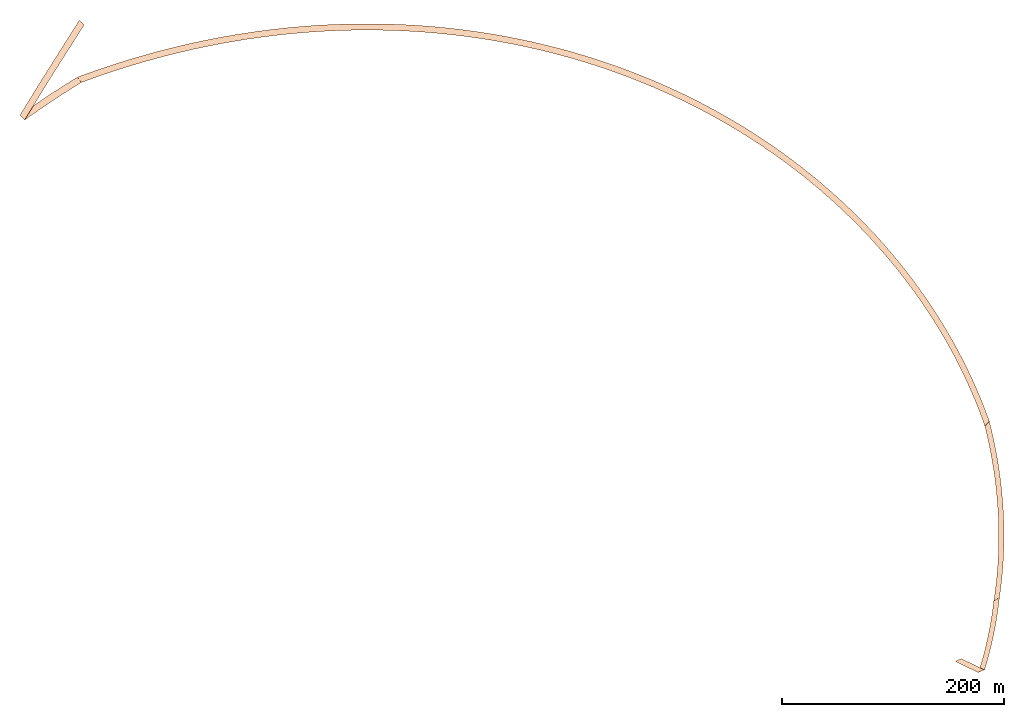
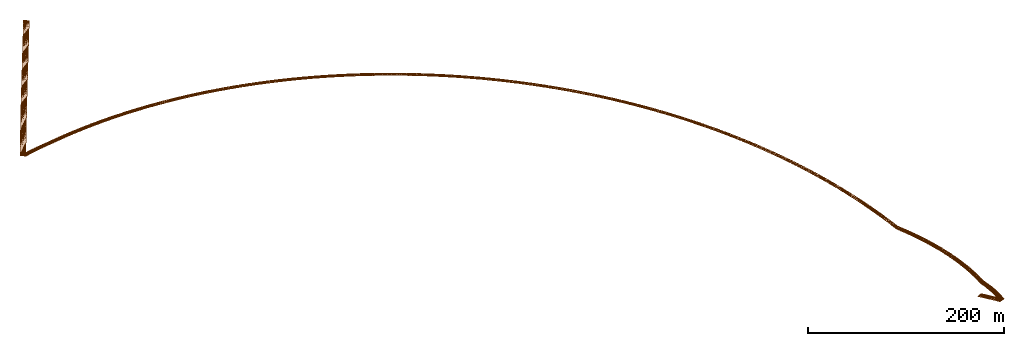
# Not in any storey: 1 pavement.
"""IFC4X3_ADD2 model written with IfcOpenShell, lengths in feet."""

from ifc_helpers import new_model, entity, si_unit, converted_unit, origin_with_axes, context, subcontext, project, spatial, element, save


model = new_model("IFC4X3_ADD2")

# Units and contexts
model_context = context("Model", 3, precision=1e-05, world=origin_with_axes())
body_context = subcontext(model_context, "Body", "Model", "MODEL_VIEW")
ifc_project = project(units=[converted_unit("LENGTHUNIT", "foot", entity("IfcReal", 0.3048), si_unit("LENGTHUNIT", "METRE"), dimensions=[1, 0, 0, 0, 0, 0, 0])], contexts=[model_context])

# Site, road, road part
site = spatial("IfcSite", under=ifc_project)
road = spatial("IfcRoad", under=site)
road_part = spatial("IfcRoadPart", under=road, UsageType="LONGITUDINAL")

# Pavement
shared_composite_curve = entity("IfcCompositeCurve", [entity("IfcCurveSegment", "CONTSAMEGRADIENT", entity("IfcAxis2Placement2D", entity("IfcCartesianPoint", [500.0, 2500.0]), entity("IfcDirection", [0.839252789970355, -0.54374144087698])), entity("IfcLengthMeasure", 0.0), entity("IfcLengthMeasure", 1956.785654), entity("IfcLine", entity("IfcCartesianPoint", [0.0, 0.0]), entity("IfcVector", entity("IfcDirection", [1.0, 0.0]), 1.0))), entity("IfcCurveSegment", "CONTSAMEGRADIENT", entity("IfcAxis2Placement2D", entity("IfcCartesianPoint", [2142.23781949347, 1436.01454900664]), entity("IfcDirection", [0.839252789970355, -0.54374144087698])), entity("IfcLengthMeasure", 0.0), entity("IfcLengthMeasure", 1919.222667), entity("IfcCircle", entity("IfcAxis2Placement2D", entity("IfcCartesianPoint", [0.0, 0.0]), entity("IfcDirection", [1.0, 0.0])), 1000.0)), entity("IfcCurveSegment", "CONTSAMEGRADIENTSAMECURVATURE", entity("IfcAxis2Placement2D", entity("IfcCartesianPoint", [3660.44604859273, 2050.73565156572]), entity("IfcDirection", [0.22453168741127, 0.974466788222281])), entity("IfcLengthMeasure", 0.0), entity("IfcLengthMeasure", 1886.905454), entity("IfcLine", entity("IfcCartesianPoint", [0.0, 0.0]), entity("IfcVector", entity("IfcDirection", [1.0, 0.0]), 1.0))), entity("IfcCurveSegment", "DISCONTINUOUS", entity("IfcAxis2Placement2D", entity("IfcCartesianPoint", [4084.11611416488, 3889.46234900421]), entity("IfcDirection", [0.22453168741127, 0.974466788222281])), entity("IfcLengthMeasure", 0.0), entity("IfcLengthMeasure", 0.0), entity("IfcLine", entity("IfcCartesianPoint", [0.0, 0.0]), entity("IfcVector", entity("IfcDirection", [1.0, 0.0]), 1.0)))], False)
shared_gradient_curve = entity("IfcGradientCurve", [entity("IfcCurveSegment", "CONTSAMEGRADIENTSAMECURVATURE", entity("IfcAxis2Placement2D", entity("IfcCartesianPoint", [0.0, 100.0]), entity("IfcDirection", [0.999846910161925, 0.0174973209278337])), entity("IfcLengthMeasure", 0.0), entity("IfcLengthMeasure", 5000.76556639081), entity("IfcLine", entity("IfcCartesianPoint", [0.0, 0.0]), entity("IfcVector", entity("IfcDirection", [1.0, 0.0]), 1.0))), entity("IfcCurveSegment", "DISCONTINUOUS", entity("IfcAxis2Placement2D", entity("IfcCartesianPoint", [5000.0, 187.5]), entity("IfcDirection", [0.999846910161925, 0.0174973209278337])), entity("IfcLengthMeasure", 0.0), entity("IfcLengthMeasure", 0.0), entity("IfcLine", entity("IfcCartesianPoint", [0.0, 0.0]), entity("IfcVector", entity("IfcDirection", [1.0, 0.0]), 1.0)))], False, shared_composite_curve)
linear_placement = entity("IfcLinearPlacement", None, entity("IfcAxis2PlacementLinear", entity("IfcPointByDistanceExpression", entity("IfcLengthMeasure", 0.0), None, None, None, shared_gradient_curve)))
gradient_curve = entity("IfcGradientCurve", [entity("IfcCurveSegment", "CONTSAMEGRADIENTSAMECURVATURE", entity("IfcAxis2Placement2D", entity("IfcCartesianPoint", [0.0, 100.0]), entity("IfcDirection", [0.999846910161925, 0.0174973209278337])), entity("IfcLengthMeasure", 0.0), entity("IfcLengthMeasure", 5000.76556639081), entity("IfcLine", entity("IfcCartesianPoint", [0.0, 0.0]), entity("IfcVector", entity("IfcDirection", [1.0, 0.0]), 1.0))), entity("IfcCurveSegment", "DISCONTINUOUS", entity("IfcAxis2Placement2D", entity("IfcCartesianPoint", [5000.0, 187.5]), entity("IfcDirection", [0.999846910161925, 0.0174973209278337])), entity("IfcLengthMeasure", 0.0), entity("IfcLengthMeasure", 0.0), entity("IfcLine", entity("IfcCartesianPoint", [0.0, 0.0]), entity("IfcVector", entity("IfcDirection", [1.0, 0.0]), 1.0)))], False, entity("IfcCompositeCurve", [entity("IfcCurveSegment", "CONTSAMEGRADIENT", entity("IfcAxis2Placement2D", entity("IfcCartesianPoint", [500.0, 2500.0]), entity("IfcDirection", [0.839252789970355, -0.54374144087698])), entity("IfcLengthMeasure", 0.0), entity("IfcLengthMeasure", 1956.785654), entity("IfcLine", entity("IfcCartesianPoint", [0.0, 0.0]), entity("IfcVector", entity("IfcDirection", [1.0, 0.0]), 1.0))), entity("IfcCurveSegment", "CONTSAMEGRADIENT", entity("IfcAxis2Placement2D", entity("IfcCartesianPoint", [2142.23781949347, 1436.01454900664]), entity("IfcDirection", [0.839252789970355, -0.54374144087698])), entity("IfcLengthMeasure", 0.0), entity("IfcLengthMeasure", 1919.222667), entity("IfcCircle", entity("IfcAxis2Placement2D", entity("IfcCartesianPoint", [0.0, 0.0]), entity("IfcDirection", [1.0, 0.0])), 1000.0)), entity("IfcCurveSegment", "CONTSAMEGRADIENTSAMECURVATURE", entity("IfcAxis2Placement2D", entity("IfcCartesianPoint", [3660.44604859273, 2050.73565156572]), entity("IfcDirection", [0.22453168741127, 0.974466788222281])), entity("IfcLengthMeasure", 0.0), entity("IfcLengthMeasure", 1886.905454), entity("IfcLine", entity("IfcCartesianPoint", [0.0, 0.0]), entity("IfcVector", entity("IfcDirection", [1.0, 0.0]), 1.0))), entity("IfcCurveSegment", "DISCONTINUOUS", entity("IfcAxis2Placement2D", entity("IfcCartesianPoint", [4084.11611416488, 3889.46234900421]), entity("IfcDirection", [0.22453168741127, 0.974466788222281])), entity("IfcLengthMeasure", 0.0), entity("IfcLengthMeasure", 0.0), entity("IfcLine", entity("IfcCartesianPoint", [0.0, 0.0]), entity("IfcVector", entity("IfcDirection", [1.0, 0.0]), 1.0)))], False))
element("IfcPavement", 1, at=linear_placement, inside=road_part, Name="Pavement", context=body_context, body=[
    entity("IfcSectionedSurface", gradient_curve, [entity("IfcAxis2PlacementLinear", entity("IfcPointByDistanceExpression", entity("IfcLengthMeasure", 1900.0), None, None, None, gradient_curve)), entity("IfcAxis2PlacementLinear", entity("IfcPointByDistanceExpression", entity("IfcLengthMeasure", 2100.0), None, None, None, gradient_curve)), entity("IfcAxis2PlacementLinear", entity("IfcPointByDistanceExpression", entity("IfcLengthMeasure", 2400.0), None, None, None, gradient_curve)), entity("IfcAxis2PlacementLinear", entity("IfcPointByDistanceExpression", entity("IfcLengthMeasure", 3800.0), None, None, None, gradient_curve)), entity("IfcAxis2PlacementLinear", entity("IfcPointByDistanceExpression", entity("IfcLengthMeasure", 4000.0), None, None, None, gradient_curve)), entity("IfcAxis2PlacementLinear", entity("IfcPointByDistanceExpression", entity("IfcLengthMeasure", 4200.0), None, None, None, gradient_curve))], [entity("IfcOpenCrossProfileDef", "CURVE", None, True, [10.0, 10.0], [0.02, -0.02]), entity("IfcOpenCrossProfileDef", "CURVE", None, True, [10.0, 10.0], [0.02, 0.02]), entity("IfcOpenCrossProfileDef", "CURVE", None, True, [10.0, 10.0], [0.06, 0.06]), entity("IfcOpenCrossProfileDef", "CURVE", None, True, [10.0, 10.0], [0.06, 0.06]), entity("IfcOpenCrossProfileDef", "CURVE", None, True, [10.0, 10.0], [0.02, 0.02]), entity("IfcOpenCrossProfileDef", "CURVE", None, True, [10.0, 10.0], [0.02, -0.02])]),
])

save(model, "model.ifc")
